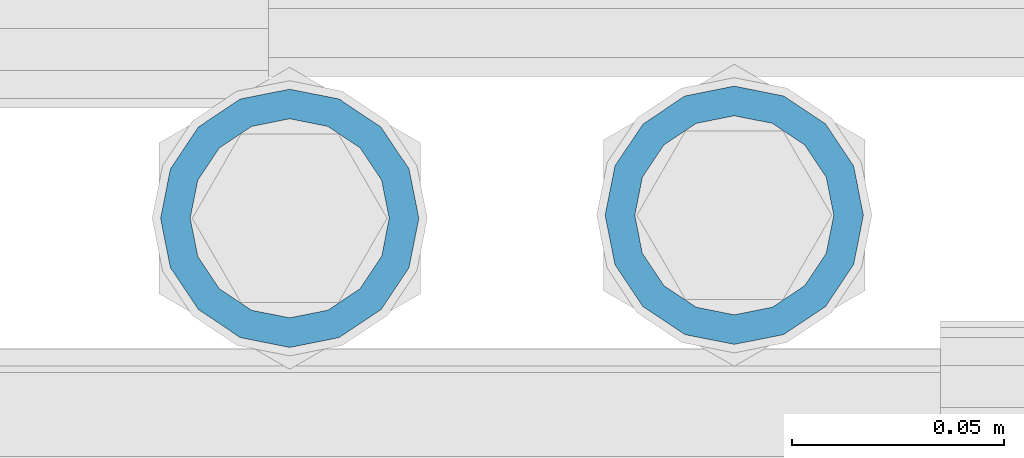
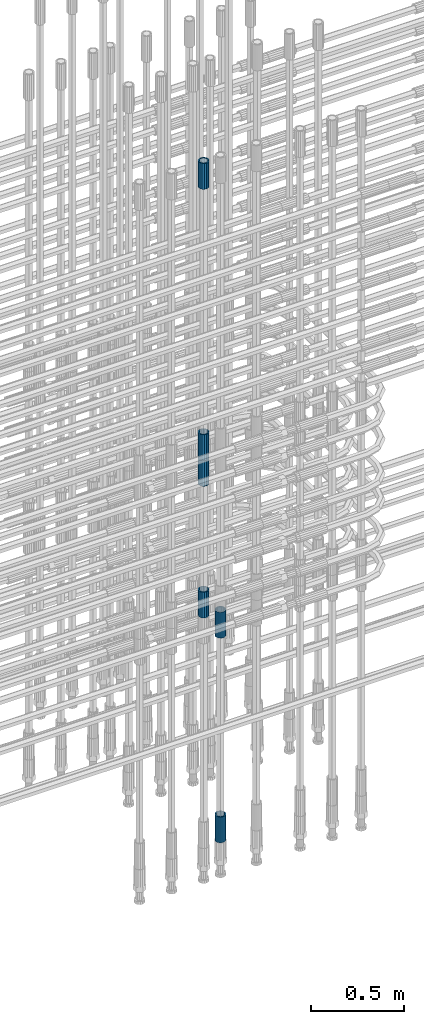
# One storey, part 23 of 119: 6 beams.
"""IFC2X3 building model written with IfcOpenShell, lengths in millimetres."""

import ifcopenshell
import ifcopenshell.guid

model = None  # the IFC model being written
_history = None  # IfcOwnerHistory: only IFC2X3 demands one
_inside = {}  # id of a spatial element -> (the spatial element, [elements in it])
_under = {}  # id of a project, library or spatial element -> (it, [spatial elements below it])
_declared = {}  # id of a project -> (the project, [libraries it declares])
_typed = {}  # id of a type object -> (the type object, [elements of that type])
_made_of = {}  # id of a material, layer set ... -> (it, [elements and type objects made of it])


def new_model(schema):
    """Start an empty IFC model of exactly this schema.

    Asked for "IFC4X3", IfcOpenShell would pick the latest addendum, in which some entities
    have other attributes; the version numbers below select the first issue.
    IFC2X3 requires an IfcOwnerHistory on every rooted entity: one is made here for all.
    """
    global model, _history
    if schema == "IFC4X3":
        model = ifcopenshell.file(schema_version=(4, 3, 0, 0))
    else:
        model = ifcopenshell.file(schema=schema)
    _inside.clear()
    _under.clear()
    _declared.clear()
    _typed.clear()
    _made_of.clear()
    _history = None
    if model.schema == "IFC2X3":
        org = make("IfcOrganization", Name="unknown")
        user = make(
            "IfcPersonAndOrganization",
            ThePerson=make("IfcPerson", FamilyName="unknown"),
            TheOrganization=org,
        )
        app = make(
            "IfcApplication",
            ApplicationDeveloper=org,
            Version="unknown",
            ApplicationFullName="unknown",
            ApplicationIdentifier="unknown",
        )
        _history = make(
            "IfcOwnerHistory",
            OwningUser=user,
            OwningApplication=app,
            ChangeAction="ADDED",
            CreationDate=0,
        )
    return model


def make(cls, **values):
    """One entity of the class cls with the attributes given. An attribute that is None is left unset."""
    return model.create_entity(
        cls, **{name: value for name, value in values.items() if value is not None}
    )


def rooted(cls, **values):
    """An entity with a GlobalId (a new one), such as an element, a storey or a relation."""
    return make(cls, GlobalId=ifcopenshell.guid.new(), OwnerHistory=_history, **values)


def si_unit(unit_type, name, prefix=None):
    """IfcSIUnit, for example si_unit("LENGTHUNIT", "METRE", prefix="MILLI")."""
    return make("IfcSIUnit", UnitType=unit_type, Prefix=prefix, Name=name)


def assignment(units):
    """IfcUnitAssignment: the units of a project."""
    return None if units is None else make("IfcUnitAssignment", Units=units)


def point(xyz):
    """IfcCartesianPoint."""
    return None if xyz is None else make("IfcCartesianPoint", Coordinates=xyz)


def direction(xyz):
    """IfcDirection."""
    return None if xyz is None else make("IfcDirection", DirectionRatios=xyz)


def frame(location, z_axis=None, x_axis=None):
    """IfcAxis2Placement3D, a coordinate frame: its origin and axes. An axis left out is left unset."""
    return make(
        "IfcAxis2Placement3D",
        Location=point(location),
        Axis=direction(z_axis),
        RefDirection=direction(x_axis),
    )


def origin_with_axes():
    """The frame at (0, 0, 0) with the z axis (0, 0, 1) and the x axis (1, 0, 0) written out."""
    return frame((0.0, 0.0, 0.0), z_axis=(0.0, 0.0, 1.0), x_axis=(1.0, 0.0, 0.0))


def place(relative_to, where):
    """IfcLocalPlacement: puts the frame where relative to a parent placement (None: the world)."""
    return make(
        "IfcLocalPlacement", PlacementRelTo=relative_to, RelativePlacement=where
    )


def context(
    kind, dimensions, precision=None, world=None, true_north=None, identifier=None
):
    """IfcGeometricRepresentationContext, for example the 3D "Model" context."""
    return make(
        "IfcGeometricRepresentationContext",
        ContextIdentifier=identifier,
        ContextType=kind,
        CoordinateSpaceDimension=dimensions,
        Precision=precision,
        WorldCoordinateSystem=world,
        TrueNorth=true_north,
    )


def subcontext(parent, identifier, kind, view, scale=None):
    """IfcGeometricRepresentationSubContext, for example "Body" below "Model"."""
    return make(
        "IfcGeometricRepresentationSubContext",
        ContextIdentifier=identifier,
        ContextType=kind,
        ParentContext=parent,
        TargetScale=scale,
        TargetView=view,
    )


def project(units=None, contexts=None):
    """IfcProject with its units and contexts."""
    return rooted(
        "IfcProject",
        Name="project",
        RepresentationContexts=contexts,
        UnitsInContext=assignment(units),
    )


def spatial(cls, under=None, at=None, **own):
    """A site, building, storey or space (cls), placed at a placement, below another one or the project."""
    s = rooted(cls, ObjectPlacement=at, **own)
    if under is not None:
        _under.setdefault(under.id(), (under, []))[1].append(s)
    return s


def faces_of(points, faces, orient=None, outer=None):
    """IfcFace entities. A face is a list of loops; a loop is a list of indices into points, from 0.

    orient and outer hold one flag for each loop. By default every Orientation is true, the
    first loop of a face is its IfcFaceOuterBound and the others are IfcFaceBound.
    """
    made = []
    for i, loops in enumerate(faces):
        bounds = []
        for j, loop in enumerate(loops):
            is_outer = j == 0 if outer is None else outer[i][j]
            bounds.append(
                make(
                    "IfcFaceOuterBound" if is_outer else "IfcFaceBound",
                    Bound=make("IfcPolyLoop", Polygon=[points[k] for k in loop]),
                    Orientation=True if orient is None else orient[i][j],
                )
            )
        made.append(make("IfcFace", Bounds=bounds))
    return made


def faceted_brep(points, faces, orient=None, outer=None, voids=None):
    """IfcFacetedBrep: a solid bounded by flat faces; with voids (closed shells), ...WithVoids."""
    shared = [point(p) for p in points]
    hull = make("IfcClosedShell", CfsFaces=faces_of(shared, faces, orient, outer))
    if voids is None:
        return make("IfcFacetedBrep", Outer=hull)
    return make(
        "IfcFacetedBrepWithVoids",
        Outer=hull,
        Voids=[
            make(cls, CfsFaces=faces_of(shared, fs, o, b)) for cls, fs, o, b in voids
        ],
    )


def shape(context_of_items, identifier, shape_type, items):
    """IfcShapeRepresentation: the items that make up one representation, for example the "Body"."""
    return make(
        "IfcShapeRepresentation",
        ContextOfItems=context_of_items,
        RepresentationIdentifier=identifier,
        RepresentationType=shape_type,
        Items=items,
    )


def material(Name=None, Category=None):
    """IfcMaterial."""
    return make("IfcMaterial", Name=Name, Category=Category)


def made_of(thing, what):
    """Note that an element or type object is made of a material, layer set ...; save() writes the relation."""
    if what is not None:
        _made_of.setdefault(what.id(), (what, []))[1].append(thing)
    return thing


def type_object(cls, material=None, **own):
    """A type object (cls), such as IfcWallType, which elements share."""
    return made_of(rooted(cls, **own), material)


def element(
    cls,
    number,
    at=None,
    inside=None,
    cuts=None,
    type_object=None,
    material=None,
    context=None,
    identifier="Body",
    shape_type=None,
    held_by="IfcProductDefinitionShape",
    body=None,
    shapes=None,
    **own,
):
    """One element of the class cls, such as IfcWall. Its Tag is "e" and its number.

    at: its placement. inside: the storey or other place that contains it. cuts: it is an
    opening in that element (IfcRelVoidsElement). A single representation is given by context,
    identifier, shape_type and body (its items); several are given by shapes. held_by: the class
    of the entity that holds the representations. save() writes the other relations.
    """
    e = rooted(cls, Tag="e%d" % number, ObjectPlacement=at, **own)
    if body is not None:
        shapes = [shape(context, identifier, shape_type, body)]
    if shapes is not None:
        e.Representation = make(held_by, Representations=shapes)
    if inside is not None:
        _inside.setdefault(inside.id(), (inside, []))[1].append(e)
    if cuts is not None:
        rooted(
            "IfcRelVoidsElement", RelatingBuildingElement=cuts, RelatedOpeningElement=e
        )
    if type_object is not None:
        _typed.setdefault(type_object.id(), (type_object, []))[1].append(e)
    return made_of(e, material)


def aggregate(whole, parts):
    """IfcRelAggregates: a whole, such as a stair, and the parts it consists of."""
    return rooted("IfcRelAggregates", RelatingObject=whole, RelatedObjects=parts)


def save(model, path):
    """Write the relations noted so far, then the file.

    IfcRelAggregates (storeys below a building ...), IfcRelContainedInSpatialStructure (elements
    in a storey), IfcRelDefinesByType, IfcRelAssociatesMaterial and IfcRelDeclares: one each for
    every whole, place, type object, material and project.
    """
    for whole, parts in _under.values():
        aggregate(whole, parts)
    for where, things in _inside.values():
        rooted(
            "IfcRelContainedInSpatialStructure",
            RelatedElements=things,
            RelatingStructure=where,
        )
    for kind, things in _typed.values():
        rooted("IfcRelDefinesByType", RelatedObjects=things, RelatingType=kind)
    for what, things in _made_of.values():
        rooted("IfcRelAssociatesMaterial", RelatedObjects=things, RelatingMaterial=what)
    for by, libraries in _declared.values():
        rooted("IfcRelDeclares", RelatingContext=by, RelatedDefinitions=libraries)
    model.write(path)


model = new_model("IFC2X3")

# Units and contexts
model_context = context("Model", 3, precision=1e-05, world=origin_with_axes())
body_context = subcontext(model_context, "Body", "Model", "MODEL_VIEW")
ifc_project = project(units=[si_unit("LENGTHUNIT", "METRE", prefix="MILLI"), si_unit("AREAUNIT", "SQUARE_METRE"), si_unit("VOLUMEUNIT", "CUBIC_METRE"), si_unit("MASSUNIT", "GRAM", prefix="KILO"), si_unit("TIMEUNIT", "SECOND"), si_unit("PLANEANGLEUNIT", "RADIAN"), si_unit("SOLIDANGLEUNIT", "STERADIAN"), si_unit("THERMODYNAMICTEMPERATUREUNIT", "DEGREE_CELSIUS"), si_unit("LUMINOUSINTENSITYUNIT", "LUMEN")], contexts=[model_context])

# Site, building, storey
site_placement = place(None, origin_with_axes())
site = spatial("IfcSite", under=ifc_project, at=site_placement, CompositionType="ELEMENT")
building_placement = place(site_placement, origin_with_axes())
building = spatial("IfcBuilding", under=site, at=building_placement, Name="Undefined", CompositionType="ELEMENT")
storey_placement = place(building_placement, origin_with_axes())
storey = spatial("IfcBuildingStorey", under=building, at=storey_placement, Name="Undefined", CompositionType="ELEMENT", Elevation=0.0)

# Beams
ifc_material = material(Name="STEEL/S275")
beam_type = type_object("IfcBeamType", PredefinedType="NOTDEFINED")
beam_1_placement = place(storey_placement, frame((2035525.00620663, 6205153.79125114, 20704.605729163), z_axis=(1.0, 0.0, 0.0), x_axis=(0.0, 0.0, 1.0)))
element("IfcBeam", 1, at=beam_1_placement, inside=storey, type_object=beam_type, material=ifc_material, Name="AG40N", context=body_context, shape_type="Brep", body=[
    faceted_brep([(1.62981450557709e-09, -23.4999999990687, 0.0), (7.45058059692383e-09, -21.7111690142192, 8.99306066057534), (170.000002125278, -21.711168999318, 8.99306066022245), (170.000002127141, -23.4999999844003, -3.66071617463604e-10), (4.65661287307739e-09, -16.6170093587134, 16.6170093578889), (170.000002122484, -16.6170093440451, 16.6170093575288), (1.86264514923096e-09, -8.99306066217832, 21.7111690140277), (170.000002118759, -8.99306064750999, 21.7111690136603), (2.3283064365387e-10, 9.31322574615479e-10, 23.5), (170.000002114102, 1.28056854009628e-08, 23.4999999996485), (-6.51925802230835e-09, 8.99306065868586, 21.7111690140241), (170.00000211224, 8.99306067335419, 21.7111690136639), (-7.45058059692383e-09, 16.6170093561523, 16.6170093578853), (170.000002109446, 16.6170093708206, 16.6170093575324), (-9.31322574615479e-09, 21.711169013055, 8.99306066057534), (170.000002108514, 21.7111690277234, 8.99306066022245), (-1.16415321826935e-09, 23.5000000009313, 0.0), (170.000002108514, 23.5000000144355, -3.66071617463604e-10), (-8.38190317153931e-09, 21.7111690151505, -8.99306066059444), (170.000002110377, 21.7111690300517, -8.9930606609546), (-5.58793544769287e-09, 16.6170093598776, -16.6170093579008), (170.000002113171, 16.6170093745459, -16.6170093582609), (-9.31322574615479e-10, 8.99306066334248, -21.7111690140396), (170.000002115965, 8.99306067801081, -21.7111690143961), (2.3283064365387e-10, 9.31322574615479e-10, -23.5), (170.00000211969, 1.7927959561348e-08, -23.5000000003843), (5.58793544769287e-09, -8.99306065752171, -21.7111690140396), (170.000002123415, -8.99306064285338, -21.7111690143961), (8.38190317153931e-09, -16.6170093549881, -16.6170093579008), (170.000002125278, -16.6170093403198, -16.6170093582646), (9.31322574615479e-09, -21.7111690121237, -8.99306066059444), (170.000002127141, -21.7111689972226, -8.9930606609546), (1.11758708953857e-08, -30.4999999990687, -9.54969436861575e-12), (1.30385160446167e-08, -28.1783257392235, -11.6718446871514), (170.000002129003, -28.1783257243223, -11.6718446875116), (170.000002129935, -30.4999999841675, -3.66071617463604e-10), (1.02445483207703e-08, -21.5667568228673, -21.5667568262129), (170.000002128072, -21.566756808199, -21.5667568265694), (7.45058059692383e-09, -11.6718446831219, -28.1783257416196), (170.000002125278, -11.6718446684536, -28.1783257419834), (3.72529029846191e-09, 3.95812094211578e-09, -30.5000000000277), (170.00000211969, 1.83936208486557e-08, -30.5000000003879), (-9.31322574615479e-10, 11.6718446905725, -28.1783257416232), (170.000002115965, 11.6718447052408, -28.1783257419797), (-6.51925802230835e-09, 21.5667568286881, -21.5667568262093), (170.000002110377, 21.5667568433564, -21.5667568265694), (-9.31322574615479e-09, 28.178325742716, -11.6718446871478), (170.000002108514, 28.1783257573843, -11.6718446875079), (-1.21071934700012e-08, 30.5, -5.91171556152403e-12), (170.000002106652, 30.5000000144355, -3.62433638656512e-10), (-1.21071934700012e-08, 28.1783257401548, 11.6718446871359), (170.00000210572, 28.1783257548232, 11.6718446867794), (-1.02445483207703e-08, 21.5667568240315, 21.5667568261974), (170.000002107583, 21.566756838467, 21.5667568258409), (-7.45058059692383e-09, 11.671844684286, 28.1783257416041), (170.000002110377, 11.6718446989544, 28.178325741244), (-2.79396772384644e-09, -2.56113708019257e-09, 30.5000000000159), (170.000002114102, 1.18743628263474e-08, 30.4999999996558), (1.86264514923096e-09, -11.6718446896411, 28.1783257416114), (170.000002118759, -11.67184467474, 28.178325741244), (7.45058059692383e-09, -21.5667568275239, 21.5667568261974), (170.000002123415, -21.5667568126228, 21.5667568258373), (1.02445483207703e-08, -28.1783257415518, 11.6718446871359), (170.000002127141, -28.1783257271163, 11.6718446867794)], [[[0, 1, 2, 3]], [[1, 4, 5, 2]], [[4, 6, 7, 5]], [[6, 8, 9, 7]], [[8, 10, 11, 9]], [[10, 12, 13, 11]], [[12, 14, 15, 13]], [[14, 16, 17, 15]], [[16, 18, 19, 17]], [[18, 20, 21, 19]], [[20, 22, 23, 21]], [[22, 24, 25, 23]], [[24, 26, 27, 25]], [[26, 28, 29, 27]], [[28, 30, 31, 29]], [[30, 0, 3, 31]], [[32, 33, 34, 35]], [[33, 36, 37, 34]], [[36, 38, 39, 37]], [[38, 40, 41, 39]], [[40, 42, 43, 41]], [[42, 44, 45, 43]], [[44, 46, 47, 45]], [[46, 48, 49, 47]], [[48, 50, 51, 49]], [[50, 52, 53, 51]], [[52, 54, 55, 53]], [[54, 56, 57, 55]], [[56, 58, 59, 57]], [[58, 60, 61, 59]], [[60, 62, 63, 61]], [[62, 32, 35, 63]], [[37, 39, 41, 43, 45, 47, 49, 51, 53, 55, 57, 59, 61, 63, 35, 34], [5, 7, 9, 11, 13, 15, 17, 19, 21, 23, 25, 27, 29, 31, 3, 2]], [[62, 60, 58, 56, 54, 52, 50, 48, 46, 44, 42, 40, 38, 36, 33, 32], [30, 28, 26, 24, 22, 20, 18, 16, 14, 12, 10, 8, 6, 4, 1, 0]]]),
])
beam_2_placement = place(storey_placement, frame((2035525.00620663, 6205153.79125114, 20007.7168583139), z_axis=(-0.99999999999998, 1.98000110685822e-07, 0.0), x_axis=(0.0, 0.0, -1.0)))
element("IfcBeam", 2, at=beam_2_placement, inside=storey, type_object=beam_type, material=ifc_material, Name="AG40N", context=body_context, shape_type="Brep", body=[
    faceted_brep([(1.62981450557709e-09, -23.4999999990687, 0.0), (7.45058059692383e-09, -21.7111690142192, 8.99306066057534), (170.000002125278, -21.711168999318, 8.99306066022245), (170.000002127141, -23.4999999844003, -3.66071617463604e-10), (4.65661287307739e-09, -16.6170093587134, 16.6170093578889), (170.000002122484, -16.6170093440451, 16.6170093575288), (1.86264514923096e-09, -8.99306066217832, 21.7111690140277), (170.000002118759, -8.99306064750999, 21.7111690136603), (2.3283064365387e-10, 9.31322574615479e-10, 23.5), (170.000002114102, 1.28056854009628e-08, 23.4999999996485), (-6.51925802230835e-09, 8.99306065868586, 21.7111690140241), (170.00000211224, 8.99306067335419, 21.7111690136639), (-7.45058059692383e-09, 16.6170093561523, 16.6170093578853), (170.000002109446, 16.6170093708206, 16.6170093575324), (-9.31322574615479e-09, 21.711169013055, 8.99306066057534), (170.000002108514, 21.7111690277234, 8.99306066022245), (-1.16415321826935e-09, 23.5000000009313, 0.0), (170.000002108514, 23.5000000144355, -3.66071617463604e-10), (-8.38190317153931e-09, 21.7111690151505, -8.99306066059444), (170.000002110377, 21.7111690300517, -8.9930606609546), (-5.58793544769287e-09, 16.6170093598776, -16.6170093579008), (170.000002113171, 16.6170093745459, -16.6170093582609), (-9.31322574615479e-10, 8.99306066334248, -21.7111690140396), (170.000002115965, 8.99306067801081, -21.7111690143961), (2.3283064365387e-10, 9.31322574615479e-10, -23.5), (170.00000211969, 1.7927959561348e-08, -23.5000000003843), (5.58793544769287e-09, -8.99306065752171, -21.7111690140396), (170.000002123415, -8.99306064285338, -21.7111690143961), (8.38190317153931e-09, -16.6170093549881, -16.6170093579008), (170.000002125278, -16.6170093403198, -16.6170093582646), (9.31322574615479e-09, -21.7111690121237, -8.99306066059444), (170.000002127141, -21.7111689972226, -8.9930606609546), (1.11758708953857e-08, -30.4999999990687, -9.54969436861575e-12), (1.30385160446167e-08, -28.1783257392235, -11.6718446871514), (170.000002129003, -28.1783257243223, -11.6718446875116), (170.000002129935, -30.4999999841675, -3.66071617463604e-10), (1.02445483207703e-08, -21.5667568228673, -21.5667568262129), (170.000002128072, -21.566756808199, -21.5667568265694), (7.45058059692383e-09, -11.6718446831219, -28.1783257416196), (170.000002125278, -11.6718446684536, -28.1783257419834), (3.72529029846191e-09, 3.95812094211578e-09, -30.5000000000277), (170.00000211969, 1.83936208486557e-08, -30.5000000003879), (-9.31322574615479e-10, 11.6718446905725, -28.1783257416232), (170.000002115965, 11.6718447052408, -28.1783257419797), (-6.51925802230835e-09, 21.5667568286881, -21.5667568262093), (170.000002110377, 21.5667568433564, -21.5667568265694), (-9.31322574615479e-09, 28.178325742716, -11.6718446871478), (170.000002108514, 28.1783257573843, -11.6718446875079), (-1.21071934700012e-08, 30.5, -5.91171556152403e-12), (170.000002106652, 30.5000000144355, -3.62433638656512e-10), (-1.21071934700012e-08, 28.1783257401548, 11.6718446871359), (170.00000210572, 28.1783257548232, 11.6718446867794), (-1.02445483207703e-08, 21.5667568240315, 21.5667568261974), (170.000002107583, 21.566756838467, 21.5667568258409), (-7.45058059692383e-09, 11.671844684286, 28.1783257416041), (170.000002110377, 11.6718446989544, 28.178325741244), (-2.79396772384644e-09, -2.56113708019257e-09, 30.5000000000159), (170.000002114102, 1.18743628263474e-08, 30.4999999996558), (1.86264514923096e-09, -11.6718446896411, 28.1783257416114), (170.000002118759, -11.67184467474, 28.178325741244), (7.45058059692383e-09, -21.5667568275239, 21.5667568261974), (170.000002123415, -21.5667568126228, 21.5667568258373), (1.02445483207703e-08, -28.1783257415518, 11.6718446871359), (170.000002127141, -28.1783257271163, 11.6718446867794)], [[[0, 1, 2, 3]], [[1, 4, 5, 2]], [[4, 6, 7, 5]], [[6, 8, 9, 7]], [[8, 10, 11, 9]], [[10, 12, 13, 11]], [[12, 14, 15, 13]], [[14, 16, 17, 15]], [[16, 18, 19, 17]], [[18, 20, 21, 19]], [[20, 22, 23, 21]], [[22, 24, 25, 23]], [[24, 26, 27, 25]], [[26, 28, 29, 27]], [[28, 30, 31, 29]], [[30, 0, 3, 31]], [[32, 33, 34, 35]], [[33, 36, 37, 34]], [[36, 38, 39, 37]], [[38, 40, 41, 39]], [[40, 42, 43, 41]], [[42, 44, 45, 43]], [[44, 46, 47, 45]], [[46, 48, 49, 47]], [[48, 50, 51, 49]], [[50, 52, 53, 51]], [[52, 54, 55, 53]], [[54, 56, 57, 55]], [[56, 58, 59, 57]], [[58, 60, 61, 59]], [[60, 62, 63, 61]], [[62, 32, 35, 63]], [[37, 39, 41, 43, 45, 47, 49, 51, 53, 55, 57, 59, 61, 63, 35, 34], [5, 7, 9, 11, 13, 15, 17, 19, 21, 23, 25, 27, 29, 31, 3, 2]], [[62, 60, 58, 56, 54, 52, 50, 48, 46, 44, 42, 40, 38, 36, 33, 32], [30, 28, 26, 24, 22, 20, 18, 16, 14, 12, 10, 8, 6, 4, 1, 0]]]),
])
beam_3_placement = place(storey_placement, frame((2035525.00620663, 6205153.79125114, 22659.985729163), z_axis=(1.0, 0.0, 0.0), x_axis=(0.0, 0.0, 1.0)))
element("IfcBeam", 3, at=beam_3_placement, inside=storey, type_object=beam_type, material=ifc_material, Name="AG40N", context=body_context, shape_type="Brep", body=[
    faceted_brep([(1.62981450557709e-09, -23.4999999990687, 0.0), (7.45058059692383e-09, -21.7111690142192, 8.99306066057534), (170.000002125278, -21.711168999318, 8.99306066022245), (170.000002127141, -23.4999999844003, -3.66071617463604e-10), (4.65661287307739e-09, -16.6170093587134, 16.6170093578889), (170.000002122484, -16.6170093440451, 16.6170093575288), (1.86264514923096e-09, -8.99306066217832, 21.7111690140277), (170.000002118759, -8.99306064750999, 21.7111690136603), (2.3283064365387e-10, 9.31322574615479e-10, 23.5), (170.000002114102, 1.28056854009628e-08, 23.4999999996485), (-6.51925802230835e-09, 8.99306065868586, 21.7111690140241), (170.00000211224, 8.99306067335419, 21.7111690136639), (-7.45058059692383e-09, 16.6170093561523, 16.6170093578853), (170.000002109446, 16.6170093708206, 16.6170093575324), (-9.31322574615479e-09, 21.711169013055, 8.99306066057534), (170.000002108514, 21.7111690277234, 8.99306066022245), (-1.16415321826935e-09, 23.5000000009313, 0.0), (170.000002108514, 23.5000000144355, -3.66071617463604e-10), (-8.38190317153931e-09, 21.7111690151505, -8.99306066059444), (170.000002110377, 21.7111690300517, -8.9930606609546), (-5.58793544769287e-09, 16.6170093598776, -16.6170093579008), (170.000002113171, 16.6170093745459, -16.6170093582609), (-9.31322574615479e-10, 8.99306066334248, -21.7111690140396), (170.000002115965, 8.99306067801081, -21.7111690143961), (2.3283064365387e-10, 9.31322574615479e-10, -23.5), (170.00000211969, 1.7927959561348e-08, -23.5000000003843), (5.58793544769287e-09, -8.99306065752171, -21.7111690140396), (170.000002123415, -8.99306064285338, -21.7111690143961), (8.38190317153931e-09, -16.6170093549881, -16.6170093579008), (170.000002125278, -16.6170093403198, -16.6170093582646), (9.31322574615479e-09, -21.7111690121237, -8.99306066059444), (170.000002127141, -21.7111689972226, -8.9930606609546), (1.11758708953857e-08, -30.4999999990687, -9.54969436861575e-12), (1.30385160446167e-08, -28.1783257392235, -11.6718446871514), (170.000002129003, -28.1783257243223, -11.6718446875116), (170.000002129935, -30.4999999841675, -3.66071617463604e-10), (1.02445483207703e-08, -21.5667568228673, -21.5667568262129), (170.000002128072, -21.566756808199, -21.5667568265694), (7.45058059692383e-09, -11.6718446831219, -28.1783257416196), (170.000002125278, -11.6718446684536, -28.1783257419834), (3.72529029846191e-09, 3.95812094211578e-09, -30.5000000000277), (170.00000211969, 1.83936208486557e-08, -30.5000000003879), (-9.31322574615479e-10, 11.6718446905725, -28.1783257416232), (170.000002115965, 11.6718447052408, -28.1783257419797), (-6.51925802230835e-09, 21.5667568286881, -21.5667568262093), (170.000002110377, 21.5667568433564, -21.5667568265694), (-9.31322574615479e-09, 28.178325742716, -11.6718446871478), (170.000002108514, 28.1783257573843, -11.6718446875079), (-1.21071934700012e-08, 30.5, -5.91171556152403e-12), (170.000002106652, 30.5000000144355, -3.62433638656512e-10), (-1.21071934700012e-08, 28.1783257401548, 11.6718446871359), (170.00000210572, 28.1783257548232, 11.6718446867794), (-1.02445483207703e-08, 21.5667568240315, 21.5667568261974), (170.000002107583, 21.566756838467, 21.5667568258409), (-7.45058059692383e-09, 11.671844684286, 28.1783257416041), (170.000002110377, 11.6718446989544, 28.178325741244), (-2.79396772384644e-09, -2.56113708019257e-09, 30.5000000000159), (170.000002114102, 1.18743628263474e-08, 30.4999999996558), (1.86264514923096e-09, -11.6718446896411, 28.1783257416114), (170.000002118759, -11.67184467474, 28.178325741244), (7.45058059692383e-09, -21.5667568275239, 21.5667568261974), (170.000002123415, -21.5667568126228, 21.5667568258373), (1.02445483207703e-08, -28.1783257415518, 11.6718446871359), (170.000002127141, -28.1783257271163, 11.6718446867794)], [[[0, 1, 2, 3]], [[1, 4, 5, 2]], [[4, 6, 7, 5]], [[6, 8, 9, 7]], [[8, 10, 11, 9]], [[10, 12, 13, 11]], [[12, 14, 15, 13]], [[14, 16, 17, 15]], [[16, 18, 19, 17]], [[18, 20, 21, 19]], [[20, 22, 23, 21]], [[22, 24, 25, 23]], [[24, 26, 27, 25]], [[26, 28, 29, 27]], [[28, 30, 31, 29]], [[30, 0, 3, 31]], [[32, 33, 34, 35]], [[33, 36, 37, 34]], [[36, 38, 39, 37]], [[38, 40, 41, 39]], [[40, 42, 43, 41]], [[42, 44, 45, 43]], [[44, 46, 47, 45]], [[46, 48, 49, 47]], [[48, 50, 51, 49]], [[50, 52, 53, 51]], [[52, 54, 55, 53]], [[54, 56, 57, 55]], [[56, 58, 59, 57]], [[58, 60, 61, 59]], [[60, 62, 63, 61]], [[62, 32, 35, 63]], [[37, 39, 41, 43, 45, 47, 49, 51, 53, 55, 57, 59, 61, 63, 35, 34], [5, 7, 9, 11, 13, 15, 17, 19, 21, 23, 25, 27, 29, 31, 3, 2]], [[62, 60, 58, 56, 54, 52, 50, 48, 46, 44, 42, 40, 38, 36, 33, 32], [30, 28, 26, 24, 22, 20, 18, 16, 14, 12, 10, 8, 6, 4, 1, 0]]]),
])
beam_4_placement = place(storey_placement, frame((2035525.00620663, 6205153.79125114, 21044.6068583132), z_axis=(-0.99999999999998, 1.98000110685822e-07, 0.0), x_axis=(0.0, 0.0, -1.0)))
element("IfcBeam", 4, at=beam_4_placement, inside=storey, type_object=beam_type, material=ifc_material, Name="AG40N", context=body_context, shape_type="Brep", body=[
    faceted_brep([(1.62981450557709e-09, -23.4999999990687, 0.0), (7.45058059692383e-09, -21.7111690142192, 8.99306066057534), (170.000002125278, -21.711168999318, 8.99306066022245), (170.000002127141, -23.4999999844003, -3.66071617463604e-10), (4.65661287307739e-09, -16.6170093587134, 16.6170093578889), (170.000002122484, -16.6170093440451, 16.6170093575288), (1.86264514923096e-09, -8.99306066217832, 21.7111690140277), (170.000002118759, -8.99306064750999, 21.7111690136603), (2.3283064365387e-10, 9.31322574615479e-10, 23.5), (170.000002114102, 1.28056854009628e-08, 23.4999999996485), (-6.51925802230835e-09, 8.99306065868586, 21.7111690140241), (170.00000211224, 8.99306067335419, 21.7111690136639), (-7.45058059692383e-09, 16.6170093561523, 16.6170093578853), (170.000002109446, 16.6170093708206, 16.6170093575324), (-9.31322574615479e-09, 21.711169013055, 8.99306066057534), (170.000002108514, 21.7111690277234, 8.99306066022245), (-1.16415321826935e-09, 23.5000000009313, 0.0), (170.000002108514, 23.5000000144355, -3.66071617463604e-10), (-8.38190317153931e-09, 21.7111690151505, -8.99306066059444), (170.000002110377, 21.7111690300517, -8.9930606609546), (-5.58793544769287e-09, 16.6170093598776, -16.6170093579008), (170.000002113171, 16.6170093745459, -16.6170093582609), (-9.31322574615479e-10, 8.99306066334248, -21.7111690140396), (170.000002115965, 8.99306067801081, -21.7111690143961), (2.3283064365387e-10, 9.31322574615479e-10, -23.5), (170.00000211969, 1.7927959561348e-08, -23.5000000003843), (5.58793544769287e-09, -8.99306065752171, -21.7111690140396), (170.000002123415, -8.99306064285338, -21.7111690143961), (8.38190317153931e-09, -16.6170093549881, -16.6170093579008), (170.000002125278, -16.6170093403198, -16.6170093582646), (9.31322574615479e-09, -21.7111690121237, -8.99306066059444), (170.000002127141, -21.7111689972226, -8.9930606609546), (1.11758708953857e-08, -30.4999999990687, -9.54969436861575e-12), (1.30385160446167e-08, -28.1783257392235, -11.6718446871514), (170.000002129003, -28.1783257243223, -11.6718446875116), (170.000002129935, -30.4999999841675, -3.66071617463604e-10), (1.02445483207703e-08, -21.5667568228673, -21.5667568262129), (170.000002128072, -21.566756808199, -21.5667568265694), (7.45058059692383e-09, -11.6718446831219, -28.1783257416196), (170.000002125278, -11.6718446684536, -28.1783257419834), (3.72529029846191e-09, 3.95812094211578e-09, -30.5000000000277), (170.00000211969, 1.83936208486557e-08, -30.5000000003879), (-9.31322574615479e-10, 11.6718446905725, -28.1783257416232), (170.000002115965, 11.6718447052408, -28.1783257419797), (-6.51925802230835e-09, 21.5667568286881, -21.5667568262093), (170.000002110377, 21.5667568433564, -21.5667568265694), (-9.31322574615479e-09, 28.178325742716, -11.6718446871478), (170.000002108514, 28.1783257573843, -11.6718446875079), (-1.21071934700012e-08, 30.5, -5.91171556152403e-12), (170.000002106652, 30.5000000144355, -3.62433638656512e-10), (-1.21071934700012e-08, 28.1783257401548, 11.6718446871359), (170.00000210572, 28.1783257548232, 11.6718446867794), (-1.02445483207703e-08, 21.5667568240315, 21.5667568261974), (170.000002107583, 21.566756838467, 21.5667568258409), (-7.45058059692383e-09, 11.671844684286, 28.1783257416041), (170.000002110377, 11.6718446989544, 28.178325741244), (-2.79396772384644e-09, -2.56113708019257e-09, 30.5000000000159), (170.000002114102, 1.18743628263474e-08, 30.4999999996558), (1.86264514923096e-09, -11.6718446896411, 28.1783257416114), (170.000002118759, -11.67184467474, 28.178325741244), (7.45058059692383e-09, -21.5667568275239, 21.5667568261974), (170.000002123415, -21.5667568126228, 21.5667568258373), (1.02445483207703e-08, -28.1783257415518, 11.6718446871359), (170.000002127141, -28.1783257271163, 11.6718446867794)], [[[0, 1, 2, 3]], [[1, 4, 5, 2]], [[4, 6, 7, 5]], [[6, 8, 9, 7]], [[8, 10, 11, 9]], [[10, 12, 13, 11]], [[12, 14, 15, 13]], [[14, 16, 17, 15]], [[16, 18, 19, 17]], [[18, 20, 21, 19]], [[20, 22, 23, 21]], [[22, 24, 25, 23]], [[24, 26, 27, 25]], [[26, 28, 29, 27]], [[28, 30, 31, 29]], [[30, 0, 3, 31]], [[32, 33, 34, 35]], [[33, 36, 37, 34]], [[36, 38, 39, 37]], [[38, 40, 41, 39]], [[40, 42, 43, 41]], [[42, 44, 45, 43]], [[44, 46, 47, 45]], [[46, 48, 49, 47]], [[48, 50, 51, 49]], [[50, 52, 53, 51]], [[52, 54, 55, 53]], [[54, 56, 57, 55]], [[56, 58, 59, 57]], [[58, 60, 61, 59]], [[60, 62, 63, 61]], [[62, 32, 35, 63]], [[37, 39, 41, 43, 45, 47, 49, 51, 53, 55, 57, 59, 61, 63, 35, 34], [5, 7, 9, 11, 13, 15, 17, 19, 21, 23, 25, 27, 29, 31, 3, 2]], [[62, 60, 58, 56, 54, 52, 50, 48, 46, 44, 42, 40, 38, 36, 33, 32], [30, 28, 26, 24, 22, 20, 18, 16, 14, 12, 10, 8, 6, 4, 1, 0]]]),
])
beam_5_placement = place(storey_placement, frame((2035630.00288785, 6205154.50579162, 19667.715729164), z_axis=(1.0, 0.0, 0.0), x_axis=(0.0, 0.0, 1.0)))
element("IfcBeam", 5, at=beam_5_placement, inside=storey, type_object=beam_type, material=ifc_material, Name="AG40N", context=body_context, shape_type="Brep", body=[
    faceted_brep([(1.62981450557709e-09, -23.4999999990687, 0.0), (7.45058059692383e-09, -21.7111690142192, 8.99306066057534), (170.000002125278, -21.711168999318, 8.99306066022245), (170.000002127141, -23.4999999844003, -3.66071617463604e-10), (4.65661287307739e-09, -16.6170093587134, 16.6170093578889), (170.000002122484, -16.6170093440451, 16.6170093575288), (1.86264514923096e-09, -8.99306066217832, 21.7111690140277), (170.000002118759, -8.99306064750999, 21.7111690136603), (2.3283064365387e-10, 9.31322574615479e-10, 23.5), (170.000002114102, 1.28056854009628e-08, 23.4999999996485), (-6.51925802230835e-09, 8.99306065868586, 21.7111690140241), (170.00000211224, 8.99306067335419, 21.7111690136639), (-7.45058059692383e-09, 16.6170093561523, 16.6170093578853), (170.000002109446, 16.6170093708206, 16.6170093575324), (-9.31322574615479e-09, 21.711169013055, 8.99306066057534), (170.000002108514, 21.7111690277234, 8.99306066022245), (-1.16415321826935e-09, 23.5000000009313, 0.0), (170.000002108514, 23.5000000144355, -3.66071617463604e-10), (-8.38190317153931e-09, 21.7111690151505, -8.99306066059444), (170.000002110377, 21.7111690300517, -8.9930606609546), (-5.58793544769287e-09, 16.6170093598776, -16.6170093579008), (170.000002113171, 16.6170093745459, -16.6170093582609), (-9.31322574615479e-10, 8.99306066334248, -21.7111690140396), (170.000002115965, 8.99306067801081, -21.7111690143961), (2.3283064365387e-10, 9.31322574615479e-10, -23.5), (170.00000211969, 1.7927959561348e-08, -23.5000000003843), (5.58793544769287e-09, -8.99306065752171, -21.7111690140396), (170.000002123415, -8.99306064285338, -21.7111690143961), (8.38190317153931e-09, -16.6170093549881, -16.6170093579008), (170.000002125278, -16.6170093403198, -16.6170093582646), (9.31322574615479e-09, -21.7111690121237, -8.99306066059444), (170.000002127141, -21.7111689972226, -8.9930606609546), (1.11758708953857e-08, -30.4999999990687, -9.54969436861575e-12), (1.30385160446167e-08, -28.1783257392235, -11.6718446871514), (170.000002129003, -28.1783257243223, -11.6718446875116), (170.000002129935, -30.4999999841675, -3.66071617463604e-10), (1.02445483207703e-08, -21.5667568228673, -21.5667568262129), (170.000002128072, -21.566756808199, -21.5667568265694), (7.45058059692383e-09, -11.6718446831219, -28.1783257416196), (170.000002125278, -11.6718446684536, -28.1783257419834), (3.72529029846191e-09, 3.95812094211578e-09, -30.5000000000277), (170.00000211969, 1.83936208486557e-08, -30.5000000003879), (-9.31322574615479e-10, 11.6718446905725, -28.1783257416232), (170.000002115965, 11.6718447052408, -28.1783257419797), (-6.51925802230835e-09, 21.5667568286881, -21.5667568262093), (170.000002110377, 21.5667568433564, -21.5667568265694), (-9.31322574615479e-09, 28.178325742716, -11.6718446871478), (170.000002108514, 28.1783257573843, -11.6718446875079), (-1.21071934700012e-08, 30.5, -5.91171556152403e-12), (170.000002106652, 30.5000000144355, -3.62433638656512e-10), (-1.21071934700012e-08, 28.1783257401548, 11.6718446871359), (170.00000210572, 28.1783257548232, 11.6718446867794), (-1.02445483207703e-08, 21.5667568240315, 21.5667568261974), (170.000002107583, 21.566756838467, 21.5667568258409), (-7.45058059692383e-09, 11.671844684286, 28.1783257416041), (170.000002110377, 11.6718446989544, 28.178325741244), (-2.79396772384644e-09, -2.56113708019257e-09, 30.5000000000159), (170.000002114102, 1.18743628263474e-08, 30.4999999996558), (1.86264514923096e-09, -11.6718446896411, 28.1783257416114), (170.000002118759, -11.67184467474, 28.178325741244), (7.45058059692383e-09, -21.5667568275239, 21.5667568261974), (170.000002123415, -21.5667568126228, 21.5667568258373), (1.02445483207703e-08, -28.1783257415518, 11.6718446871359), (170.000002127141, -28.1783257271163, 11.6718446867794)], [[[0, 1, 2, 3]], [[1, 4, 5, 2]], [[4, 6, 7, 5]], [[6, 8, 9, 7]], [[8, 10, 11, 9]], [[10, 12, 13, 11]], [[12, 14, 15, 13]], [[14, 16, 17, 15]], [[16, 18, 19, 17]], [[18, 20, 21, 19]], [[20, 22, 23, 21]], [[22, 24, 25, 23]], [[24, 26, 27, 25]], [[26, 28, 29, 27]], [[28, 30, 31, 29]], [[30, 0, 3, 31]], [[32, 33, 34, 35]], [[33, 36, 37, 34]], [[36, 38, 39, 37]], [[38, 40, 41, 39]], [[40, 42, 43, 41]], [[42, 44, 45, 43]], [[44, 46, 47, 45]], [[46, 48, 49, 47]], [[48, 50, 51, 49]], [[50, 52, 53, 51]], [[52, 54, 55, 53]], [[54, 56, 57, 55]], [[56, 58, 59, 57]], [[58, 60, 61, 59]], [[60, 62, 63, 61]], [[62, 32, 35, 63]], [[37, 39, 41, 43, 45, 47, 49, 51, 53, 55, 57, 59, 61, 63, 35, 34], [5, 7, 9, 11, 13, 15, 17, 19, 21, 23, 25, 27, 29, 31, 3, 2]], [[62, 60, 58, 56, 54, 52, 50, 48, 46, 44, 42, 40, 38, 36, 33, 32], [30, 28, 26, 24, 22, 20, 18, 16, 14, 12, 10, 8, 6, 4, 1, 0]]]),
])
beam_6_placement = place(storey_placement, frame((2035630.00288785, 6205154.50579162, 18490.9668583148), z_axis=(-0.99999999999998, 1.98000110685822e-07, 0.0), x_axis=(0.0, 0.0, -1.0)))
element("IfcBeam", 6, at=beam_6_placement, inside=storey, type_object=beam_type, material=ifc_material, Name="AG40N", context=body_context, shape_type="Brep", body=[
    faceted_brep([(1.62981450557709e-09, -23.4999999990687, 0.0), (7.45058059692383e-09, -21.7111690142192, 8.99306066057534), (170.000002125278, -21.711168999318, 8.99306066022245), (170.000002127141, -23.4999999844003, -3.66071617463604e-10), (4.65661287307739e-09, -16.6170093587134, 16.6170093578889), (170.000002122484, -16.6170093440451, 16.6170093575288), (1.86264514923096e-09, -8.99306066217832, 21.7111690140277), (170.000002118759, -8.99306064750999, 21.7111690136603), (2.3283064365387e-10, 9.31322574615479e-10, 23.5), (170.000002114102, 1.28056854009628e-08, 23.4999999996485), (-6.51925802230835e-09, 8.99306065868586, 21.7111690140241), (170.00000211224, 8.99306067335419, 21.7111690136639), (-7.45058059692383e-09, 16.6170093561523, 16.6170093578853), (170.000002109446, 16.6170093708206, 16.6170093575324), (-9.31322574615479e-09, 21.711169013055, 8.99306066057534), (170.000002108514, 21.7111690277234, 8.99306066022245), (-1.16415321826935e-09, 23.5000000009313, 0.0), (170.000002108514, 23.5000000144355, -3.66071617463604e-10), (-8.38190317153931e-09, 21.7111690151505, -8.99306066059444), (170.000002110377, 21.7111690300517, -8.9930606609546), (-5.58793544769287e-09, 16.6170093598776, -16.6170093579008), (170.000002113171, 16.6170093745459, -16.6170093582609), (-9.31322574615479e-10, 8.99306066334248, -21.7111690140396), (170.000002115965, 8.99306067801081, -21.7111690143961), (2.3283064365387e-10, 9.31322574615479e-10, -23.5), (170.00000211969, 1.7927959561348e-08, -23.5000000003843), (5.58793544769287e-09, -8.99306065752171, -21.7111690140396), (170.000002123415, -8.99306064285338, -21.7111690143961), (8.38190317153931e-09, -16.6170093549881, -16.6170093579008), (170.000002125278, -16.6170093403198, -16.6170093582646), (9.31322574615479e-09, -21.7111690121237, -8.99306066059444), (170.000002127141, -21.7111689972226, -8.9930606609546), (1.11758708953857e-08, -30.4999999990687, -9.54969436861575e-12), (1.30385160446167e-08, -28.1783257392235, -11.6718446871514), (170.000002129003, -28.1783257243223, -11.6718446875116), (170.000002129935, -30.4999999841675, -3.66071617463604e-10), (1.02445483207703e-08, -21.5667568228673, -21.5667568262129), (170.000002128072, -21.566756808199, -21.5667568265694), (7.45058059692383e-09, -11.6718446831219, -28.1783257416196), (170.000002125278, -11.6718446684536, -28.1783257419834), (3.72529029846191e-09, 3.95812094211578e-09, -30.5000000000277), (170.00000211969, 1.83936208486557e-08, -30.5000000003879), (-9.31322574615479e-10, 11.6718446905725, -28.1783257416232), (170.000002115965, 11.6718447052408, -28.1783257419797), (-6.51925802230835e-09, 21.5667568286881, -21.5667568262093), (170.000002110377, 21.5667568433564, -21.5667568265694), (-9.31322574615479e-09, 28.178325742716, -11.6718446871478), (170.000002108514, 28.1783257573843, -11.6718446875079), (-1.21071934700012e-08, 30.5, -5.91171556152403e-12), (170.000002106652, 30.5000000144355, -3.62433638656512e-10), (-1.21071934700012e-08, 28.1783257401548, 11.6718446871359), (170.00000210572, 28.1783257548232, 11.6718446867794), (-1.02445483207703e-08, 21.5667568240315, 21.5667568261974), (170.000002107583, 21.566756838467, 21.5667568258409), (-7.45058059692383e-09, 11.671844684286, 28.1783257416041), (170.000002110377, 11.6718446989544, 28.178325741244), (-2.79396772384644e-09, -2.56113708019257e-09, 30.5000000000159), (170.000002114102, 1.18743628263474e-08, 30.4999999996558), (1.86264514923096e-09, -11.6718446896411, 28.1783257416114), (170.000002118759, -11.67184467474, 28.178325741244), (7.45058059692383e-09, -21.5667568275239, 21.5667568261974), (170.000002123415, -21.5667568126228, 21.5667568258373), (1.02445483207703e-08, -28.1783257415518, 11.6718446871359), (170.000002127141, -28.1783257271163, 11.6718446867794)], [[[0, 1, 2, 3]], [[1, 4, 5, 2]], [[4, 6, 7, 5]], [[6, 8, 9, 7]], [[8, 10, 11, 9]], [[10, 12, 13, 11]], [[12, 14, 15, 13]], [[14, 16, 17, 15]], [[16, 18, 19, 17]], [[18, 20, 21, 19]], [[20, 22, 23, 21]], [[22, 24, 25, 23]], [[24, 26, 27, 25]], [[26, 28, 29, 27]], [[28, 30, 31, 29]], [[30, 0, 3, 31]], [[32, 33, 34, 35]], [[33, 36, 37, 34]], [[36, 38, 39, 37]], [[38, 40, 41, 39]], [[40, 42, 43, 41]], [[42, 44, 45, 43]], [[44, 46, 47, 45]], [[46, 48, 49, 47]], [[48, 50, 51, 49]], [[50, 52, 53, 51]], [[52, 54, 55, 53]], [[54, 56, 57, 55]], [[56, 58, 59, 57]], [[58, 60, 61, 59]], [[60, 62, 63, 61]], [[62, 32, 35, 63]], [[37, 39, 41, 43, 45, 47, 49, 51, 53, 55, 57, 59, 61, 63, 35, 34], [5, 7, 9, 11, 13, 15, 17, 19, 21, 23, 25, 27, 29, 31, 3, 2]], [[62, 60, 58, 56, 54, 52, 50, 48, 46, 44, 42, 40, 38, 36, 33, 32], [30, 28, 26, 24, 22, 20, 18, 16, 14, 12, 10, 8, 6, 4, 1, 0]]]),
])

save(model, "model.ifc")
